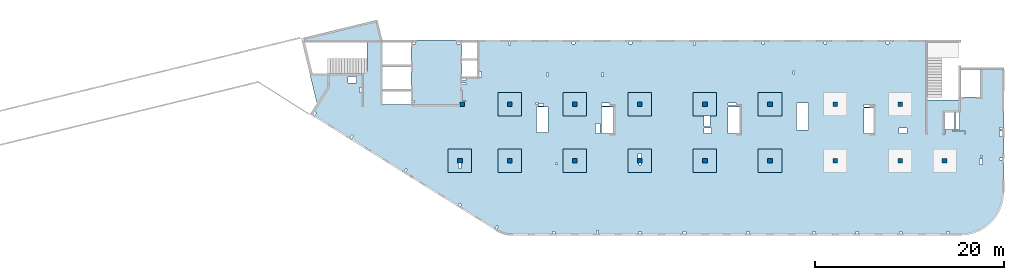
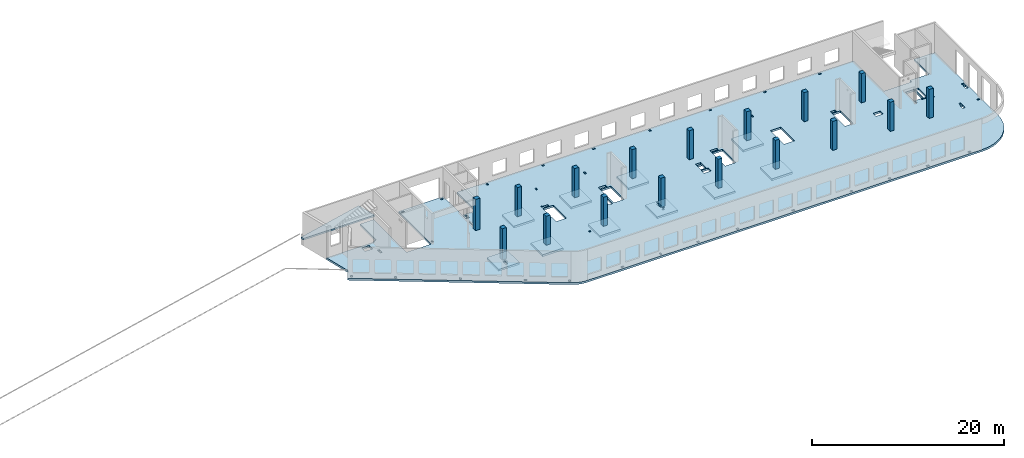
# One storey, part 1 of 8: 17 columns, 13 slabs.
"""IFC4 building model written with IfcOpenShell, lengths in millimetres."""

from ifc_helpers import new_model, entity, si_unit, converted_unit, derived_unit, direction, frame, origin, place, context, subcontext, project, spatial, indexed_curve, outline, extrude, source, transform, mapped, material, type_object, type_shapes, element, save


model = new_model("IFC4")

# Units and contexts
model_context = context("Model", 3, precision=0.01, world=origin(), true_north=direction((6.12303176911189e-17, 1.0)))
plan_context = context("Plan", 3, precision=0.01, world=origin(), true_north=direction((6.12303176911189e-17, 1.0)))
body_context = subcontext(model_context, "Body", "Model", "MODEL_VIEW")
ifc_project = project(units=[si_unit("LENGTHUNIT", "METRE", prefix="MILLI"), si_unit("AREAUNIT", "SQUARE_METRE"), si_unit("VOLUMEUNIT", "CUBIC_METRE"), converted_unit("PLANEANGLEUNIT", "DEGREE", entity("IfcRatioMeasure", 0.0174532925199433), si_unit("PLANEANGLEUNIT", "RADIAN"), dimensions=[0, 0, 0, 0, 0, 0, 0]), si_unit("MASSUNIT", "GRAM", prefix="KILO"), derived_unit("MASSDENSITYUNIT", [(si_unit("MASSUNIT", "GRAM", prefix="KILO"), 1), (si_unit("LENGTHUNIT", "METRE"), -3)]), derived_unit("MOMENTOFINERTIAUNIT", [(si_unit("LENGTHUNIT", "METRE"), 4)]), si_unit("TIMEUNIT", "SECOND"), si_unit("FREQUENCYUNIT", "HERTZ"), si_unit("THERMODYNAMICTEMPERATUREUNIT", "DEGREE_CELSIUS"), derived_unit("THERMALTRANSMITTANCEUNIT", [(si_unit("MASSUNIT", "GRAM", prefix="KILO"), 1), (si_unit("THERMODYNAMICTEMPERATUREUNIT", "KELVIN"), -1), (si_unit("TIMEUNIT", "SECOND"), -3)]), derived_unit("VOLUMETRICFLOWRATEUNIT", [(si_unit("LENGTHUNIT", "METRE"), 3), (si_unit("TIMEUNIT", "SECOND"), -1)]), derived_unit("MASSFLOWRATEUNIT", [(si_unit("MASSUNIT", "GRAM", prefix="KILO"), 1), (si_unit("TIMEUNIT", "SECOND"), -1)]), derived_unit("ROTATIONALFREQUENCYUNIT", [(si_unit("TIMEUNIT", "SECOND"), -1)]), si_unit("ELECTRICCURRENTUNIT", "AMPERE"), si_unit("ELECTRICVOLTAGEUNIT", "VOLT"), si_unit("POWERUNIT", "WATT"), si_unit("FORCEUNIT", "NEWTON", prefix="KILO"), si_unit("ILLUMINANCEUNIT", "LUX"), si_unit("LUMINOUSFLUXUNIT", "LUMEN"), si_unit("LUMINOUSINTENSITYUNIT", "CANDELA"), derived_unit("USERDEFINED", [(si_unit("MASSUNIT", "GRAM", prefix="KILO"), -1), (si_unit("LENGTHUNIT", "METRE"), -2), (si_unit("TIMEUNIT", "SECOND"), 3), (si_unit("LUMINOUSFLUXUNIT", "LUMEN"), 1)]), derived_unit("LINEARVELOCITYUNIT", [(si_unit("LENGTHUNIT", "METRE"), 1), (si_unit("TIMEUNIT", "SECOND"), -1)]), si_unit("PRESSUREUNIT", "PASCAL"), derived_unit("USERDEFINED", [(si_unit("LENGTHUNIT", "METRE"), -2), (si_unit("MASSUNIT", "GRAM", prefix="KILO"), 1), (si_unit("TIMEUNIT", "SECOND"), -2)]), derived_unit("LINEARFORCEUNIT", [(si_unit("MASSUNIT", "GRAM", prefix="KILO"), 1), (si_unit("LENGTHUNIT", "METRE"), 1), (si_unit("TIMEUNIT", "SECOND"), -2), (si_unit("LENGTHUNIT", "METRE"), -1)]), derived_unit("PLANARFORCEUNIT", [(si_unit("MASSUNIT", "GRAM", prefix="KILO"), 1), (si_unit("LENGTHUNIT", "METRE"), 1), (si_unit("TIMEUNIT", "SECOND"), -2), (si_unit("LENGTHUNIT", "METRE"), -2)])], contexts=[model_context, plan_context])

# Site, building, storey
site_placement = place(None, origin())
site = spatial("IfcSite", under=ifc_project, at=site_placement, CompositionType="ELEMENT")
building_placement = place(site_placement, origin())
building = spatial("IfcBuilding", under=site, at=building_placement, CompositionType="ELEMENT")
storey_placement = place(building_placement, frame((0.0, 0.0, 24000.0)))
storey = spatial("IfcBuildingStorey", under=building, at=storey_placement, CompositionType="ELEMENT", Elevation=24000.0)

# Columns
ifc_material = material()
column_type_1 = type_object("IfcColumnType", PredefinedType="COLUMN", material=ifc_material)
shared_shape_1 = source(origin(), body_context, "Body", "SweptSolid", [
    extrude(outline(indexed_curve([(-249.999999999999, -249.999999999999), (249.999999999999, -249.999999999999), (249.999999999999, 249.999999999999), (-249.999999999999, 249.999999999999), (-249.999999999999, -249.999999999999)], self_intersect=False)), frame((16149.9995239258, 13699.9993759155, 23850.0), z_axis=(0.0, 0.0, 1.0), x_axis=(0.0, -1.0, 0.0)), (0.0, 0.0, 1.0), 3950.0),
])
type_shapes(column_type_1, [shared_shape_1])
column_1_placement = place(storey_placement, frame((0.0, 0.0, -24000.0)))
element("IfcColumn", 1, at=column_1_placement, inside=storey, type_object=column_type_1, PredefinedType="COLUMN", context=body_context, shape_type="MappedRepresentation", body=[
    mapped(shared_shape_1, transform((0.0, 0.0, 0.0), scale=1.0)),
])
column_type_2 = type_object("IfcColumnType", PredefinedType="COLUMN", material=ifc_material)
shared_shape_2 = source(origin(), body_context, "Body", "SweptSolid", [
    extrude(outline(indexed_curve([(-249.999999999999, -249.999999999999), (250.000000000001, -249.999999999999), (249.999999999999, 249.999999999999), (-250.000000000001, 249.999999999999), (-249.999999999999, -249.999999999999)], self_intersect=False)), frame((15899.9995239258, 7699.99922635584, 23850.0), z_axis=(0.0, 0.0, 1.0), x_axis=(0.0, -1.0, 0.0)), (0.0, 0.0, 1.0), 3950.0),
])
type_shapes(column_type_2, [shared_shape_2])
column_2_placement = place(storey_placement, frame((0.0, 0.0, -24000.0)))
element("IfcColumn", 2, at=column_2_placement, inside=storey, type_object=column_type_2, PredefinedType="COLUMN", context=body_context, shape_type="MappedRepresentation", body=[
    mapped(shared_shape_2, transform((0.0, 0.0, 0.0), scale=1.0)),
])
column_type_3 = type_object("IfcColumnType", PredefinedType="COLUMN", material=ifc_material)
shared_shape_3 = source(origin(), body_context, "Body", "SweptSolid", [
    extrude(outline(indexed_curve([(-250.0, -250.0), (250.0, -250.0), (250.0, 250.0), (-250.0, 250.0), (-250.0, -250.0)], self_intersect=False)), frame((0.0, 0.0, 23850.0), z_axis=(0.0, 0.0, 1.0), x_axis=(0.0, -1.0, 0.0)), (0.0, 0.0, 1.0), 3700.0),
])
type_shapes(column_type_3, [shared_shape_3])
for number, where in (
    (3, (21170.0002685547, 7699.99922635582, -24000.0)),
    (4, (28070.0002685547, 7699.9992263558, -24000.0)),
    (5, (34970.0002685547, 7699.99922635577, -24000.0)),
    (6, (41870.0002685547, 7699.99922635575, -24000.0)),
    (7, (48770.0002685547, 7699.99922635573, -24000.0)),
    (8, (55670.0002685547, 7699.99922635571, -24000.0)),
    (9, (62570.0002685547, 7699.99922635568, -24000.0)),
    (10, (67270.0002685547, 7699.99922635567, -24000.0)),
    (11, (62570.0002685547, 13699.9992263555, -24000.0)),
    (12, (55670.0002685547, 13699.9992263555, -24000.0)),
    (13, (48770.0002685547, 13699.9992263556, -24000.0)),
    (14, (41870.0002685547, 13699.9992263556, -24000.0)),
    (15, (34970.0002685547, 13699.9992263556, -24000.0)),
    (16, (28070.0002685547, 13699.9992263556, -24000.0)),
    (17, (21170.0002685547, 13699.9992263556, -24000.0)),
):
    element("IfcColumn", number, at=place(storey_placement, frame(where)), inside=storey, type_object=column_type_3, PredefinedType="COLUMN", context=body_context, shape_type="MappedRepresentation", body=[
        mapped(shared_shape_3, transform((0.0, 0.0, 0.0), scale=1.0)),
    ])

# Slabs
slab_type_1 = type_object("IfcSlabType", PredefinedType="FLOOR", material=ifc_material)
slab_1_placement = place(storey_placement, origin())
element("IfcSlab", 18, at=slab_1_placement, inside=storey, type_object=slab_type_1, material=ifc_material, PredefinedType="FLOOR", context=body_context, shape_type="SweptSolid", body=[
    extrude(outline(indexed_curve([(-4603.53286028, -15653.7908371281), (-4449.01513314947, -15744.4716102884), (-4289.66236892735, -15826.3582829116), (-4125.97455687157, -15899.1939253055), (-3958.46528799564, -15962.7500065188), (-3787.66014361249, -16016.8271113857), (-3614.09504625731, -16061.2555662162), (-3438.31457816345, -16095.8959711683), (-3260.87027256743, -16120.6396376323), (-3082.31888320434, -16135.4089292555), (-2903.22063742329, -16140.1575055354), (44597.126521692, -16140.1575055355), (45316.7249329339, -16083.5238823425), (46018.6044430807, -15915.0175205227), (46685.4824491883, -15638.7876059446), (47300.9382015049, -15261.6358358598), (47849.817136828, -14792.8489385425), (48318.6040341452, -14243.9700032194), (48695.75580423, -13628.5142509028), (48971.9857188081, -12961.6362447953), (49140.4920806279, -12259.7567346484), (49197.1257038209, -11540.1583234066), (49197.125703821, 1629.84249446453), (46697.125703821, 1629.84249446453), (46697.1257038209, -1470.15750553546), (44397.1265216921, -1470.15750553546), (44397.1265216921, -1810.15750553546), (41057.1265216921, -1810.15750553545), (41057.1265216921, 4559.84313383174), (-6647.87347830793, 4559.8431338319), (-6647.87347830794, 659.842494464898), (-8272.87347830793, 659.842494464902), (-8272.87347830792, 4559.84313383174), (-13672.8734783079, 4559.84313383175), (-13672.8734783079, -2290.15750553506), (-16672.8734783079, -2290.15750553505), (-16672.8734783079, 4559.84313383174), (-18302.8734783079, 4559.84313383174), (-18302.8734783079, 1219.84313383174), (-18622.8734783079, 1219.84313383174), (-18622.8734783079, 1019.84249446499), (-24402.3399879828, 1019.84249446501), (-23636.4879258287, -2121.97831515316), (-24373.0138341888, -3300.68916159189), (-4603.53286028, -15653.7908371281)], self_intersect=False), holes=[indexed_curve([(-19412.8734783079, 19.8424944649914), (-20312.8734783079, 19.8424944649914), (-20312.8734783079, 719.842494464993), (-19412.8734783079, 719.84249446499), (-19412.8734783079, 19.8424944649914)], self_intersect=False), indexed_curve([(-18872.8734783079, -455.157505535005), (-18872.8734783079, -1015.15750553501), (-19122.8734783079, -1015.15750553501), (-19122.8734783079, -455.157505535005), (-18872.8734783079, -455.157505535005)], self_intersect=False), indexed_curve([(-23853.6420978495, -3035.63633762671), (-23684.031549094, -3141.61870290911), (-23843.0050970176, -3396.03452604239), (-24012.6156457731, -3290.05216075998), (-23853.6420978495, -3035.63633762671)], self_intersect=False), indexed_curve([(-19944.1189490349, -5478.52985738614), (-19774.5084002794, -5584.51222266855), (-19933.481948203, -5838.92804580182), (-20103.0924969585, -5732.94568051942), (-19944.1189490349, -5478.52985738614)], self_intersect=False), indexed_curve([(-14211.2824010985, -9060.73380393143), (-14041.671852343, -9166.71616921384), (-14200.6454002666, -9421.13199234711), (-14370.2559490221, -9315.14962706471), (-14211.2824010985, -9060.73380393143)], self_intersect=False), indexed_curve([(-8539.91756324108, -12722.4439065904), (-8285.50174010781, -12881.417454514), (-8391.48410539021, -13051.0280032695), (-8645.89992852348, -12892.0544553459), (-8539.91756324108, -12722.4439065904)], self_intersect=False), indexed_curve([(-4568.92270434749, -15085.8312702362), (-4399.31215559197, -15191.8136355186), (-4558.28570351558, -15446.2294586518), (-4727.89625227109, -15340.2470933694), (-4568.92270434749, -15085.8312702362)], self_intersect=False), indexed_curve([(1627.12652169203, -15940.1575055352), (1327.12652169203, -15940.1575055352), (1327.12652169203, -15740.1575055352), (1627.12652169203, -15740.1575055352), (1627.12652169203, -15940.1575055352)], self_intersect=False), indexed_curve([(6222.12652169204, -15940.1575055352), (6022.12652169204, -15940.1575055352), (6022.12652169204, -15640.1575055352), (6222.12652169204, -15640.1575055352), (6222.12652169204, -15940.1575055352)], self_intersect=False), indexed_curve([(10747.126521692, -15940.1575055352), (10447.126521692, -15940.1575055352), (10447.126521692, -15740.1575055352), (10747.126521692, -15740.1575055352), (10747.126521692, -15940.1575055352)], self_intersect=False), indexed_curve([(15497.126521692, -15940.1575055352), (15197.126521692, -15940.1575055352), (15197.126521692, -15740.1575055352), (15497.126521692, -15740.1575055352), (15497.126521692, -15940.1575055352)], self_intersect=False), indexed_curve([(22197.126521692, -15940.1575055352), (21897.126521692, -15940.1575055352), (21897.126521692, -15740.1575055352), (22197.126521692, -15740.1575055352), (22197.126521692, -15940.1575055352)], self_intersect=False), indexed_curve([(29197.1265216921, -15940.1575055352), (28897.126521692, -15940.1575055352), (28897.126521692, -15740.1575055352), (29197.1265216921, -15740.1575055352), (29197.1265216921, -15940.1575055352)], self_intersect=False), indexed_curve([(33797.126521692, -15940.1575055352), (33497.1265216921, -15940.1575055352), (33497.1265216921, -15740.1575055352), (33797.1265216921, -15740.1575055352), (33797.126521692, -15940.1575055352)], self_intersect=False), indexed_curve([(38397.1265216921, -15940.1575055353), (38097.126521692, -15940.1575055353), (38097.126521692, -15740.1575055353), (38397.1265216921, -15740.1575055353), (38397.1265216921, -15940.1575055353)], self_intersect=False), indexed_curve([(43397.126521692, -15940.1575055353), (43097.126521692, -15940.1575055353), (43097.126521692, -15740.1575055353), (43397.126521692, -15740.1575055353), (43397.126521692, -15940.1575055353)], self_intersect=False), indexed_curve([(-13172.8734783079, 4359.84313383174), (-13172.8734783079, 4159.84313383174), (-13472.8734783079, 4159.84313383174), (-13472.8734783079, 4359.84313383174), (-13172.8734783079, 4359.84313383174)], self_intersect=False), indexed_curve([(-13272.8734783079, -2040.15750553505), (-13472.8734783079, -2040.15750553505), (-13472.8734783079, -1840.15750553505), (-13272.8734783079, -1840.15750553505), (-13272.8734783079, -2040.15750553505)], self_intersect=False), indexed_curve([(-8772.87347830792, 4359.84313383174), (-8472.87347830792, 4359.84313383174), (-8472.87347830792, 4159.84313383174), (-8772.87347830792, 4159.84313383174), (-8772.87347830792, 4359.84313383174)], self_intersect=False), indexed_curve([(-7842.87347830793, 459.842494464904), (-7842.87347830793, 259.842494464902), (-8272.87347830793, 259.842494464902), (-8272.87347830793, 459.842494464902), (-7842.87347830793, 459.842494464904)], self_intersect=False), indexed_curve([(-7842.87347830793, 34.8424944649014), (-7842.87347830793, -125.157505535097), (-8272.87347830793, -125.157505535097), (-8272.87347830793, 34.8424944649014), (-7842.87347830793, 34.8424944649014)], self_intersect=False), indexed_curve([(-8272.87347830794, -1970.1575055351), (-8272.87347830793, -780.157505535095), (-8192.87347830793, -780.157505535095), (-8192.87347830794, -1890.15750553509), (-7852.87347830794, -1890.15750553509), (-7852.87347830794, -1970.15750553509), (-8272.87347830794, -1970.1575055351)], self_intersect=False), indexed_curve([(-6197.87347830793, 659.842494464898), (-6447.87347830793, 659.842494464898), (-6447.87347830793, 1219.8424944649), (-6197.87347830793, 1219.8424944649), (-6197.87347830793, 659.842494464898)], self_intersect=False), indexed_curve([(-3302.87347830793, 4359.84313383174), (-3202.87347830793, 4359.84313383174), (-3102.87347830793, 4359.84249446488), (-3102.87347830793, 4059.84313383174), (-3302.87347830793, 4059.84313383174), (-3302.87347830793, 4359.84313383174)], self_intersect=False), indexed_curve([(3397.12652169207, 4359.84249446484), (3697.12652169207, 4359.84249446483), (3697.12652169207, 4159.84249446483), (3397.12652169207, 4159.84249446483), (3397.12652169207, 4359.84249446484)], self_intersect=False), indexed_curve([(9472.12652169208, 4359.84249446481), (9772.12652169208, 4359.84249446482), (9772.12652169207, 4159.84249446481), (9472.12652169207, 4159.84249446481), (9472.12652169208, 4359.84249446481)], self_intersect=False), indexed_curve([(23522.1265216921, 4359.84249446477), (23822.1265216921, 4359.84249446476), (23822.1265216921, 4159.84249446476), (23522.1265216921, 4159.84249446477), (23522.1265216921, 4359.84249446477)], self_intersect=False), indexed_curve([(16272.1265216921, 4359.84249446475), (16472.1265216921, 4359.84249446474), (16472.1265216921, 4059.84249446474), (16272.1265216921, 4059.84249446474), (16272.1265216921, 4359.84249446475)], self_intersect=False), indexed_curve([(30097.1265216921, 4359.84249446474), (30397.1265216921, 4359.84249446473), (30397.1265216921, 4159.84249446474), (30097.1265216921, 4159.84249446474), (30097.1265216921, 4359.84249446474)], self_intersect=False), indexed_curve([(36697.1265216921, 4359.84249446472), (36997.1265216921, 4359.84249446471), (36997.1265216921, 4159.84249446472), (36697.1265216921, 4159.84249446472), (36697.1265216921, 4359.84249446472)], self_intersect=False), indexed_curve([(897.126521692066, 1059.84313383174), (897.126521692066, 739.843133831733), (697.126521692064, 739.843133831735), (697.126521692064, 1059.84313383174), (897.126521692066, 1059.84313383174)], self_intersect=False), indexed_curve([(6747.12652169207, 1079.84313383185), (6747.12652169207, 719.843133831856), (6547.12652169207, 719.843133831856), (6547.12652169207, 1079.84313383185), (6747.12652169207, 1079.84313383185)], self_intersect=False), indexed_curve([(26987.1265216921, 1309.84249446548), (26987.1265216921, 959.842494465525), (26837.1265216921, 959.842494465525), (26837.1265216921, 1309.84249446548), (26987.1265216921, 1309.84249446548)], self_intersect=False), indexed_curve([(44067.1265216921, -4915.15750553544), (44067.1265216921, -3110.15750553544), (44457.1265216921, -3110.15750553545), (44457.1265216921, -4915.15750553544), (44067.1265216921, -4915.15750553544)], self_intersect=False), indexed_curve([(42987.1265216921, -5035.15750553544), (42987.1265216921, -5375.15750553544), (42907.1265216921, -5375.15750553545), (42907.1265216921, -5315.1575055354), (42907.1265216921, -5035.15750553544), (42987.1265216921, -5035.15750553544)], self_intersect=False), indexed_curve([(45107.1265216921, -5035.15750553544), (45107.1265216921, -5375.15750553544), (45027.1265216921, -5375.15750553544), (45027.1265216921, -5115.15750553544), (43727.1265216921, -5115.15750553544), (43727.1265216921, -5035.15750553544), (45107.1265216921, -5035.15750553544)], self_intersect=False), indexed_curve([(48697.1257038209, -8130.15750553549), (48697.1257038209, -7930.15750553549), (48997.1257038209, -7930.15750553549), (48997.1257038209, -8130.15750553549), (48697.1257038209, -8130.15750553549)], self_intersect=False), indexed_curve([(48697.1257038209, -4890.15750553548), (48697.1257038209, -4690.15750553548), (48997.125703821, -4690.15750553549), (48997.125703821, -4890.15750553548), (48697.1257038209, -4890.15750553548)], self_intersect=False), indexed_curve([(48697.1257038209, -5655.1575055355), (48697.1257038209, -5055.15750553549), (48997.1257038209, -5055.15750553549), (48997.125703821, -5655.1575055355), (48697.1257038209, -5655.1575055355)], self_intersect=False), indexed_curve([(46907.1257038209, -8030.15750553448), (46907.1257038209, -8640.15750553548), (46607.1257038209, -8640.15750553548), (46607.1257038209, -8030.15750553448), (46907.1257038209, -8030.15750553448)], self_intersect=False), indexed_curve([(46917.1257038209, -7650.1575055345), (46917.1257038209, -7850.15750553452), (46717.1257038209, -7850.15750553452), (46717.1257038209, -7650.15750553449), (46917.1257038209, -7650.1575055345)], self_intersect=False), indexed_curve([(38912.1265216921, -4755.15750553541), (38912.1265216921, -5355.1575055354), (38082.1265216921, -5355.1575055354), (38082.1265216921, -4755.15750553541), (38912.1265216921, -4755.15750553541)], self_intersect=False), indexed_curve([(34357.1265216921, -5315.15750553539), (34357.1265216921, -2645.15750553538), (35357.1265216921, -2645.15750553538), (35357.1265216921, -5315.1575055354), (34357.1265216921, -5315.15750553539)], self_intersect=False), indexed_curve([(34357.1265216921, -2240.15750553538), (34957.1265216921, -2240.15750553538), (34957.1265216921, -2525.15750553538), (34357.1265216921, -2525.15750553538), (34357.1265216921, -2240.15750553538)], self_intersect=False), indexed_curve([(28477.1265216921, -2105.15750553533), (28477.1265216921, -4965.15750553535), (27217.1265216921, -4965.15750553535), (27217.1265216921, -2105.15750553533), (28477.1265216921, -2105.15750553533)], self_intersect=False), indexed_curve([(19937.1265216921, -5315.1573559755), (19937.1265216921, -2540.1573559755), (21197.1265216921, -2540.1573559755), (21197.1265216921, -5315.15735597549), (19937.1265216921, -5315.1573559755)], self_intersect=False), indexed_curve([(19937.1265216921, -2390.1575055353), (19937.1265216921, -2100.15750553529), (20797.1265216921, -2100.15750553529), (20797.1265216921, -2390.15750553529), (19937.1265216921, -2390.1575055353)], self_intersect=False), indexed_curve([(17407.1265216921, -3490.15750553534), (17497.1265216921, -3490.15750553534), (18027.1265216921, -3490.15750553534), (18027.1265216921, -4610.15750553534), (17407.1265216921, -4610.15750553534), (17407.1265216921, -3490.15750553534)], self_intersect=False), indexed_curve([(17382.1265216921, -4755.15750553535), (18212.1265216921, -4755.15750553535), (18212.1265216921, -5355.15750553534), (17382.1265216921, -5355.15750553534), (17382.1265216921, -4755.15750553535)], self_intersect=False), indexed_curve([(6537.12652169207, -5315.15735597545), (6537.12652169207, -2540.15735597545), (7797.12652169206, -2540.15735597545), (7797.12652169207, -5315.15735597545), (6537.12652169207, -5315.15735597545)], self_intersect=False), indexed_curve([(6537.12652169207, -2100.1575055352), (7397.12652169206, -2100.1575055352), (7397.12652169206, -2420.15750553519), (6537.12652169206, -2420.15750553519), (6537.12652169207, -2100.1575055352)], self_intersect=False), indexed_curve([(5917.12652169207, -5355.15735597546), (5917.12652169206, -4265.15735597545), (6377.12652169207, -4265.15735597545), (6377.12652169207, -5355.15735597546), (5917.12652169207, -5355.15735597546)], self_intersect=False), indexed_curve([(1877.12652169205, -8450.15750553516), (1877.12652169204, -8650.15750553516), (1677.12652169204, -8650.15750553516), (1677.12652169204, -8450.15750553516), (1877.12652169205, -8450.15750553516)], self_intersect=False), indexed_curve([(877.126521692058, -2540.15750553514), (877.126521692058, -5250.15750553514), (-382.873478307942, -5250.15750553514), (-382.873478307942, -2540.15750553514), (877.126521692058, -2540.15750553514)], self_intersect=False), indexed_curve([(-202.873478307996, -2250.15750553514), (-402.87347830802, -2250.15750553514), (-402.873478308024, -2050.15750553452), (-202.873478308, -2050.15750553452), (-202.873478307996, -2250.15750553514)], self_intersect=False), indexed_curve([(397.126521692006, -2420.15750553515), (-162.873478308005, -2420.15750553515), (-162.873478308009, -2170.15750553515), (397.126521692006, -2170.15750553515), (397.126521692006, -2420.15750553515)], self_intersect=False), indexed_curve([(43947.1265216921, -3110.15750553544), (43947.1265216921, -4915.15750553545), (42907.1265216921, -4915.15750553544), (42907.1265216921, -3110.15750553544), (43947.1265216921, -3110.15750553544)], self_intersect=False), indexed_curve([(-8632.87347830795, -8490.15750553509), (-8472.87347830795, -8490.15750553509), (-8382.87347830796, -8490.15750553509), (-8382.87347830795, -9050.15750553509), (-8632.87347830794, -9050.15750553509), (-8632.87347830795, -8490.15750553509)], self_intersect=False), indexed_curve([(10497.1265216921, -8490.15750553522), (10597.126521692, -8490.15750553522), (10697.1265216921, -8490.15750553522), (10697.1265216921, -8690.15750553522), (10497.1265216921, -8690.15750553523), (10497.1265216921, -8490.15750553522)], self_intersect=False), indexed_curve([(10417.126521692, -7950.15750553522), (10417.126521692, -7440.15750553522), (10747.126521692, -7440.15750553522), (10747.126521692, -7950.15750553522), (10417.126521692, -7950.15750553522)], self_intersect=False)]), frame((24372.8737468626, 15940.1567318909, -400.0)), (0.0, 0.0, 1.0), 249.999999999999),
])
slab_type_2 = type_object("IfcSlabType", PredefinedType="FLOOR", material=ifc_material)
slab_2_placement = place(storey_placement, origin())
element("IfcSlab", 19, at=slab_2_placement, inside=storey, type_object=slab_type_2, material=ifc_material, PredefinedType="FLOOR", context=body_context, shape_type="SweptSolid", body=[
    extrude(outline(indexed_curve([(-2965.94379251259, -516.869103588944), (5577.68320951875, -516.869103588944), (5667.33346675777, -149.08913967664), (-2396.54091108099, 1816.56555403243), (-2916.58818017036, -316.869103588947), (-2965.94379251259, -316.869103588947), (-2965.94379251259, -516.869103588944)], self_intersect=False)), frame((4734.05647604212, 20816.8689693116, 550.0), z_axis=(0.0, 0.0, -1.0), x_axis=(-1.0, 0.0, 0.0)), (0.0, 0.0, 1.0), 200.000000000002),
])
slab_type_3 = type_object("IfcSlabType", PredefinedType="FLOOR", material=ifc_material)
slab_3_placement = place(storey_placement, origin())
element("IfcSlab", 20, at=slab_3_placement, inside=storey, type_object=slab_type_3, material=ifc_material, PredefinedType="FLOOR", context=body_context, shape_type="SweptSolid", body=[
    extrude(outline(indexed_curve([(-999.999999999999, -1250.0), (1500.0, -1250.0), (1500.0, 1250.0), (-999.999999999999, 1250.0), (-1000.0, -1.73258740687743e-12), (-999.999999999999, -1250.0)], self_intersect=False), holes=[indexed_curve([(500.000000000006, 89.9999999999999), (1060.0, 90.0000000000009), (1060.0, -159.999999999999), (500.000000000007, -160.0), (500.000000000006, 89.9999999999999)], self_intersect=False)]), frame((15900.0002685547, 7949.99922635584, -650.0), z_axis=(0.0, 0.0, 1.0), x_axis=(0.0, -1.0, 0.0)), (0.0, 0.0, 1.0), 249.999999999999),
])
slab_type_4 = type_object("IfcSlabType", PredefinedType="FLOOR", material=ifc_material)
slab_4_placement = place(storey_placement, origin())
element("IfcSlab", 21, at=slab_4_placement, inside=storey, type_object=slab_type_4, material=ifc_material, PredefinedType="FLOOR", context=body_context, shape_type="SweptSolid", body=[
    extrude(outline(indexed_curve([(-1250.0, -1250.0), (1250.0, -1250.0), (1250.0, 1250.0), (-1250.0, 1250.0), (-1250.0, -1250.0)], self_intersect=False)), frame((21170.0002685547, 7699.99922635582, -400.0), z_axis=(0.0, 0.0, -1.0), x_axis=(0.0, 1.0, 0.0)), (0.0, 0.0, 1.0), 249.999999999999),
])
slab_type_5 = type_object("IfcSlabType", PredefinedType="FLOOR", material=ifc_material)
slab_5_placement = place(storey_placement, origin())
element("IfcSlab", 22, at=slab_5_placement, inside=storey, type_object=slab_type_5, material=ifc_material, PredefinedType="FLOOR", context=body_context, shape_type="SweptSolid", body=[
    extrude(outline(indexed_curve([(-1250.0, -1250.0), (1250.0, -1250.0), (1250.0, 1250.0), (-1250.0, 1250.0), (-1250.0, -1250.0)], self_intersect=False)), frame((28070.0002685547, 7699.9992263558, -400.0), z_axis=(0.0, 0.0, -1.0), x_axis=(0.0, 1.0, 0.0)), (0.0, 0.0, 1.0), 249.999999999999),
])
slab_type_6 = type_object("IfcSlabType", PredefinedType="FLOOR", material=ifc_material)
slab_6_placement = place(storey_placement, origin())
element("IfcSlab", 23, at=slab_6_placement, inside=storey, type_object=slab_type_6, material=ifc_material, PredefinedType="FLOOR", context=body_context, shape_type="SweptSolid", body=[
    extrude(outline(indexed_curve([(-999.999999999999, -1250.00000000001), (1500.0, -1250.00000000001), (1500.0, 1250.0), (-999.999999999999, 1250.0), (-1000.0, -6.064055924071e-12), (-999.999999999999, -1250.00000000001)], self_intersect=False), holes=[indexed_curve([(500.000000000073, 99.9999999999998), (700.000000000076, 100.0), (700.000000000076, -100.000000000002), (500.000000000074, -100.000000000002), (500.000000000073, 99.9999999999998)], self_intersect=False), indexed_curve([(-549.999999999928, 149.999999999991), (-39.9999999999262, 149.999999999992), (-39.9999999999256, -180.000000000007), (-549.999999999928, -180.000000000008), (-549.999999999928, 149.999999999991)], self_intersect=False)]), frame((34970.0002685547, 7949.99922635578, -650.0), z_axis=(0.0, 0.0, 1.0), x_axis=(0.0, -1.0, 0.0)), (0.0, 0.0, 1.0), 249.999999999999),
])
slab_type_7 = type_object("IfcSlabType", PredefinedType="FLOOR", material=ifc_material)
slab_7_placement = place(storey_placement, origin())
element("IfcSlab", 24, at=slab_7_placement, inside=storey, type_object=slab_type_7, material=ifc_material, PredefinedType="FLOOR", context=body_context, shape_type="SweptSolid", body=[
    extrude(outline(indexed_curve([(-1250.0, -1250.0), (1250.0, -1250.0), (1250.0, 1250.0), (-1250.0, 1250.0), (-1250.0, -1250.0)], self_intersect=False)), frame((41870.0002685547, 7699.99922635575, -400.0), z_axis=(0.0, 0.0, -1.0), x_axis=(0.0, 1.0, 0.0)), (0.0, 0.0, 1.0), 249.999999999999),
])
slab_type_8 = type_object("IfcSlabType", PredefinedType="FLOOR", material=ifc_material)
slab_8_placement = place(storey_placement, origin())
element("IfcSlab", 25, at=slab_8_placement, inside=storey, type_object=slab_type_8, material=ifc_material, PredefinedType="FLOOR", context=body_context, shape_type="SweptSolid", body=[
    extrude(outline(indexed_curve([(-1250.0, -1250.0), (1250.0, -1250.0), (1250.0, 1250.0), (-1250.0, 1250.0), (-1250.0, -1250.0)], self_intersect=False)), frame((48770.0002685547, 7699.99922635573, -400.0), z_axis=(0.0, 0.0, -1.0), x_axis=(0.0, 1.0, 0.0)), (0.0, 0.0, 1.0), 249.999999999999),
])
slab_type_9 = type_object("IfcSlabType", PredefinedType="FLOOR", material=ifc_material)
slab_9_placement = place(storey_placement, origin())
element("IfcSlab", 26, at=slab_9_placement, inside=storey, type_object=slab_type_9, material=ifc_material, PredefinedType="FLOOR", context=body_context, shape_type="SweptSolid", body=[
    extrude(outline(indexed_curve([(-1250.0, -1250.0), (1250.0, -1250.0), (1250.0, 1250.0), (-1250.0, 1250.0), (-1250.0, -1250.0)], self_intersect=False)), frame((48770.0002685547, 13699.9992263556, -400.0), z_axis=(0.0, 0.0, -1.0), x_axis=(0.0, 1.0, 0.0)), (0.0, 0.0, 1.0), 249.999999999999),
])
slab_type_10 = type_object("IfcSlabType", PredefinedType="FLOOR", material=ifc_material)
slab_10_placement = place(storey_placement, origin())
element("IfcSlab", 27, at=slab_10_placement, inside=storey, type_object=slab_type_10, material=ifc_material, PredefinedType="FLOOR", context=body_context, shape_type="SweptSolid", body=[
    extrude(outline(indexed_curve([(-1250.0, -1250.0), (1250.0, -1250.0), (1250.0, 1250.0), (-1250.0, 1250.0), (-1250.0, -1250.0)], self_intersect=False)), frame((41870.0002685547, 13699.9992263556, -400.0), z_axis=(0.0, 0.0, -1.0), x_axis=(0.0, 1.0, 0.0)), (0.0, 0.0, 1.0), 249.999999999999),
])
slab_type_11 = type_object("IfcSlabType", PredefinedType="FLOOR", material=ifc_material)
slab_11_placement = place(storey_placement, origin())
element("IfcSlab", 28, at=slab_11_placement, inside=storey, type_object=slab_type_11, material=ifc_material, PredefinedType="FLOOR", context=body_context, shape_type="SweptSolid", body=[
    extrude(outline(indexed_curve([(-1250.0, -1250.0), (1250.0, -1250.0), (1250.0, 1250.0), (-1250.0, 1250.0), (-1250.0, -1250.0)], self_intersect=False)), frame((34970.0002685547, 13699.9992263556, -400.0), z_axis=(0.0, 0.0, -1.0), x_axis=(0.0, 1.0, 0.0)), (0.0, 0.0, 1.0), 249.999999999999),
])
slab_type_12 = type_object("IfcSlabType", PredefinedType="FLOOR", material=ifc_material)
slab_12_placement = place(storey_placement, origin())
element("IfcSlab", 29, at=slab_12_placement, inside=storey, type_object=slab_type_12, material=ifc_material, PredefinedType="FLOOR", context=body_context, shape_type="SweptSolid", body=[
    extrude(outline(indexed_curve([(-1250.0, -1250.0), (1250.0, -1250.0), (1250.0, 1250.0), (-1250.0, 1250.0), (-1250.0, -1250.0)], self_intersect=False)), frame((28070.0002685547, 13699.9992263556, -400.0), z_axis=(0.0, 0.0, -1.0), x_axis=(0.0, 1.0, 0.0)), (0.0, 0.0, 1.0), 249.999999999999),
])
slab_type_13 = type_object("IfcSlabType", PredefinedType="FLOOR", material=ifc_material)
slab_13_placement = place(storey_placement, origin())
element("IfcSlab", 30, at=slab_13_placement, inside=storey, type_object=slab_type_13, material=ifc_material, PredefinedType="FLOOR", context=body_context, shape_type="SweptSolid", body=[
    extrude(outline(indexed_curve([(-1250.0, -1250.0), (1250.0, -1250.0), (1250.0, 1250.0), (-1250.0, 1250.0), (-1250.0, -1250.0)], self_intersect=False)), frame((21170.0002685547, 13699.9992263556, -400.0), z_axis=(0.0, 0.0, -1.0), x_axis=(0.0, 1.0, 0.0)), (0.0, 0.0, 1.0), 249.999999999999),
])

save(model, "model.ifc")
